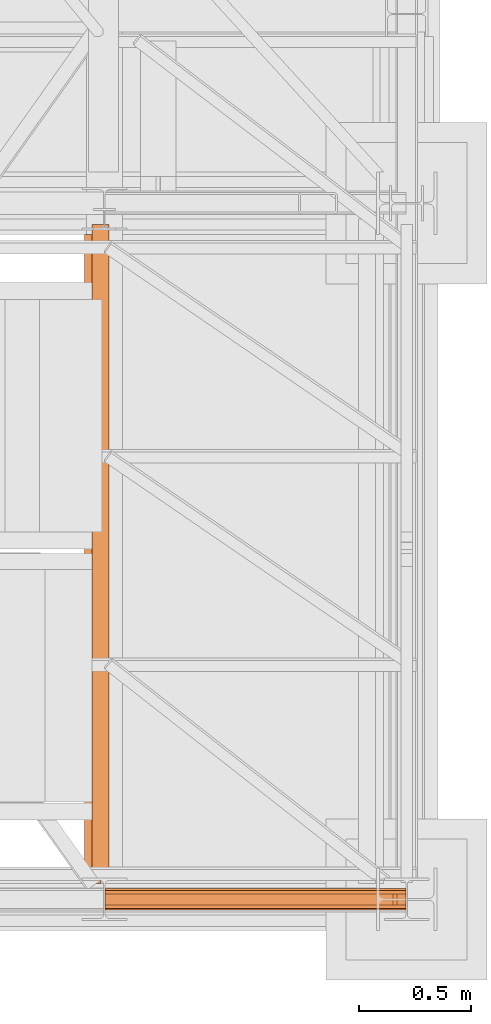
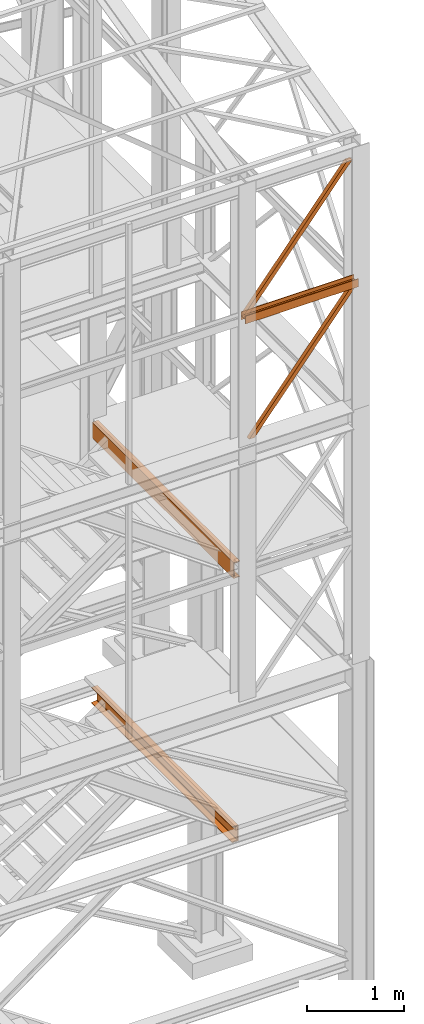
# One storey, part 47 of 208: 6 proxies.
"""IFC2X3 building model written with IfcOpenShell, lengths in millimetres."""

from ifc_helpers import new_model, entity, si_unit, converted_unit, frame, origin, origin_with_axes, place, context, subcontext, project, spatial, faceted_brep, element, save


model = new_model("IFC2X3")

# Units and contexts
model_context = context("Model", 3, precision=1e-05, world=origin())
plan_context = context("Plan", 3, precision=1e-05, world=origin())
body_context = subcontext(model_context, "Body", "Model", "MODEL_VIEW")
ifc_project = project(units=[si_unit("LENGTHUNIT", "METRE", prefix="MILLI"), converted_unit("PLANEANGLEUNIT", "DEGREE", entity("IfcPlaneAngleMeasure", 0.0174532925199433), si_unit("PLANEANGLEUNIT", "RADIAN"), dimensions=[0, 0, 0, 0, 0, 0, 0]), si_unit("AREAUNIT", "SQUARE_METRE"), si_unit("VOLUMEUNIT", "CUBIC_METRE")], contexts=[model_context, plan_context])

# Building, storey
building_placement = place(None, origin())
building = spatial("IfcBuilding", under=ifc_project, at=building_placement, CompositionType="COMPLEX")
storey_placement = place(building_placement, origin_with_axes())
storey = spatial("IfcBuildingStorey", under=building, at=storey_placement, Name="Geschoss", CompositionType="ELEMENT")

# Proxies
proxy_1_placement = place(storey_placement, frame((5351.504968595713, -25220.57439031787, 9979.990000745052), z_axis=(0.0, 0.0, 1.0), x_axis=(1.0, 0.0, 0.0)))
element("IfcBuildingElementProxy", 1, at=proxy_1_placement, inside=storey, context=body_context, shape_type="Brep", body=[
    faceted_brep([(0.01000000000021828, 8.0099999999984, 0.01000000000021828), (0.01000000000021828, 8.0099999999984, 47.51000000000022), (0.01000000000021828, 88.0099999999984, 47.51000000000022), (0.01000000000021828, 88.0099999999984, 0.01000000000021828), (0.01000000000021828, 96.0099999999984, 0.01000000000021828), (0.01000000000021828, 96.0099999999984, 100.0100000000002), (0.01000000000021828, 88.0099999999984, 100.0100000000002), (0.01000000000021828, 88.0099999999984, 52.51000000000022), (0.01000000000021828, 8.0099999999984, 52.51000000000022), (0.01000000000021828, 8.0099999999984, 100.0100000000002), (0.01000000000021828, 0.00999999999839929, 100.0100000000002), (0.01000000000021828, 0.00999999999839929, 0.01000000000021828), (0.01000000000021828, 0.00999999999839929, 0.01000000000021828), (1343.509999865887, 0.00999999999839929, 0.01000000000021828), (1343.509999865887, 8.0099999999984, 0.01000000000021828), (0.01000000000021828, 8.0099999999984, 0.01000000000021828), (0.01000000000021828, 0.00999999999839929, 100.0100000000002), (1343.509999865887, 0.00999999999839929, 100.0100000000002), (1343.509999865887, 0.00999999999839929, 0.01000000000021828), (0.01000000000021828, 0.00999999999839929, 0.01000000000021828), (0.01000000000021828, 8.0099999999984, 100.0100000000002), (1343.509999865887, 8.0099999999984, 100.0100000000002), (1343.509999865887, 0.00999999999839929, 100.0100000000002), (0.01000000000021828, 0.00999999999839929, 100.0100000000002), (0.01000000000021828, 8.0099999999984, 52.51000000000022), (1343.509999865887, 8.0099999999984, 52.51000000000022), (1343.509999865887, 8.0099999999984, 100.0100000000002), (0.01000000000021828, 8.0099999999984, 100.0100000000002), (0.01000000000021828, 88.0099999999984, 52.51000000000022), (1343.509999865887, 88.0099999999984, 52.51000000000022), (1343.509999865887, 8.0099999999984, 52.51000000000022), (0.01000000000021828, 8.0099999999984, 52.51000000000022), (0.01000000000021828, 88.0099999999984, 100.0100000000002), (1343.509999865887, 88.0099999999984, 100.0100000000002), (1343.509999865887, 88.0099999999984, 52.51000000000022), (0.01000000000021828, 88.0099999999984, 52.51000000000022), (0.01000000000021828, 96.0099999999984, 100.0100000000002), (1343.509999865887, 96.0099999999984, 100.0100000000002), (1343.509999865887, 88.0099999999984, 100.0100000000002), (0.01000000000021828, 88.0099999999984, 100.0100000000002), (0.01000000000021828, 96.0099999999984, 0.01000000000021828), (1343.509999865887, 96.0099999999984, 0.01000000000021828), (1343.509999865887, 96.0099999999984, 100.0100000000002), (0.01000000000021828, 96.0099999999984, 100.0100000000002), (0.01000000000021828, 88.0099999999984, 0.01000000000021828), (1343.509999865887, 88.0099999999984, 0.01000000000021828), (1343.509999865887, 96.0099999999984, 0.01000000000021828), (0.01000000000021828, 96.0099999999984, 0.01000000000021828), (0.01000000000021828, 88.0099999999984, 47.51000000000022), (1343.509999865887, 88.0099999999984, 47.51000000000022), (1343.509999865887, 88.0099999999984, 0.01000000000021828), (0.01000000000021828, 88.0099999999984, 0.01000000000021828), (0.01000000000021828, 8.0099999999984, 47.51000000000022), (1343.509999865887, 8.0099999999984, 47.51000000000022), (1343.509999865887, 88.0099999999984, 47.51000000000022), (0.01000000000021828, 88.0099999999984, 47.51000000000022), (0.01000000000021828, 8.0099999999984, 0.01000000000021828), (1343.509999865887, 8.0099999999984, 0.01000000000021828), (1343.509999865887, 8.0099999999984, 47.51000000000022), (0.01000000000021828, 8.0099999999984, 47.51000000000022), (1343.509999865887, 8.0099999999984, 0.01000000000021828), (1343.509999865887, 0.00999999999839929, 0.01000000000021828), (1343.509999865887, 0.00999999999839929, 100.0100000000002), (1343.509999865887, 8.0099999999984, 100.0100000000002), (1343.509999865887, 8.0099999999984, 52.51000000000022), (1343.509999865887, 88.0099999999984, 52.51000000000022), (1343.509999865887, 88.0099999999984, 100.0100000000002), (1343.509999865887, 96.0099999999984, 100.0100000000002), (1343.509999865887, 96.0099999999984, 0.01000000000021828), (1343.509999865887, 88.0099999999984, 0.01000000000021828), (1343.509999865887, 88.0099999999984, 47.51000000000022), (1343.509999865887, 8.0099999999984, 47.51000000000022)], [[[0, 1, 2, 3, 4, 5, 6, 7, 8, 9, 10, 11]], [[12, 13, 14, 15]], [[16, 17, 18, 19]], [[20, 21, 22, 23]], [[24, 25, 26, 27]], [[28, 29, 30, 31]], [[32, 33, 34, 35]], [[36, 37, 38, 39]], [[40, 41, 42, 43]], [[44, 45, 46, 47]], [[48, 49, 50, 51]], [[52, 53, 54, 55]], [[56, 57, 58, 59]], [[60, 61, 62, 63, 64, 65, 66, 67, 68, 69, 70, 71]]], orient=[[False], [False], [False], [False], [False], [False], [False], [False], [False], [False], [False], [False], [False], [False]]),
])
proxy_2_placement = place(storey_placement, frame((5409.555422962857, -25197.57439069041, 8496.989995894723), z_axis=(0.0, 0.0, 1.0), x_axis=(1.0, 0.0, 0.0)))
element("IfcBuildingElementProxy", 2, at=proxy_2_placement, inside=storey, context=body_context, shape_type="Brep", body=[
    faceted_brep([(0.009999999999308784, 50.01000074505646, 0.01000000000021828), (1244.693738884314, 50.01000074505646, 1530.51000485033), (1244.693738884314, 0.00999999999839929, 1530.51000485033), (0.01000000000112777, 0.00999999999839929, 0.01000000000021828), (64.45727517743671, 50.01000074505646, 0.01000000000021828), (1285.459545498749, 50.01000074505646, 1501.390569432124), (1285.459545498749, 50.01000074505646, 1530.51000485033), (1244.693738884314, 50.01000074505646, 1530.51000485033), (0.009999999999308784, 50.01000074505646, 0.01000000000021828), (64.45727517743671, 0.00999999999839929, 0.01000000000021828), (1285.45954549875, 0.00999999999839929, 1501.390569432124), (1285.459545498749, 50.01000074505646, 1501.390569432124), (64.45727517743671, 50.01000074505646, 0.01000000000021828), (0.01000000000112777, 0.00999999999839929, 0.01000000000021828), (1244.693738884314, 0.00999999999839929, 1530.51000485033), (1285.45954549875, 0.00999999999839929, 1530.510004850332), (1285.45954549875, 0.00999999999839929, 1501.390569432124), (64.45727517743671, 0.00999999999839929, 0.01000000000021828), (1244.693738884314, 0.00999999999839929, 1530.51000485033), (1244.693738884314, 50.01000074505646, 1530.51000485033), (1285.459545498749, 50.01000074505646, 1530.51000485033), (1285.45954549875, 0.00999999999839929, 1530.510004850332), (1285.459545498749, 50.01000074505646, 1530.51000485033), (1285.459545498749, 50.01000074505646, 1501.390569432124), (1285.45954549875, 0.00999999999839929, 1501.390569432124), (1285.45954549875, 0.00999999999839929, 1530.510004850332), (0.009999999999308784, 50.01000074505646, 0.01000000000021828), (0.01000000000112777, 0.00999999999839929, 0.01000000000021828), (64.45727517743671, 0.00999999999839929, 0.01000000000021828), (64.45727517743671, 50.01000074505646, 0.01000000000021828)], [[[0, 1, 2, 3]], [[4, 5, 6, 7, 8]], [[9, 10, 11, 12]], [[13, 14, 15, 16, 17]], [[18, 19, 20, 21]], [[22, 23, 24, 25]], [[26, 27, 28, 29]]], orient=[[False], [False], [False], [False], [False], [False], [False]]),
])
proxy_3_placement = place(storey_placement, frame((5351.504968595718, -25197.57439069041, 10044.49000051408), z_axis=(0.0, 0.0, 1.0), x_axis=(1.0, 0.0, 0.0)))
element("IfcBuildingElementProxy", 3, at=proxy_3_placement, inside=storey, context=body_context, shape_type="Brep", body=[
    faceted_brep([(0.01000000000112777, 0.00999999999839929, 41.12943667735271), (0.01000000000021828, 50.01000074505646, 41.12943667735271), (1220.994077882662, 50.01000074505646, 1542.487636147871), (1220.994077882662, 0.00999999999839929, 1542.487636147871), (0.01000000000021828, 50.01000074505646, 41.12943667735271), (0.01000000000021828, 50.01000074505646, 0.01000000000021828), (31.01676944585506, 50.01000074505646, 0.01000000000021828), (1285.459539439544, 50.01000074505646, 1542.509998658894), (1226.759995164574, 50.01000074505646, 1542.509998658894), (1220.994077882662, 50.01000074505646, 1542.487636147871), (31.01676944585506, 50.01000074505646, 0.01000000000021828), (31.01676944585506, 0.00999999999839929, 0.01000000000021828), (1285.459539439544, 0.00999999999839929, 1542.509998658894), (1285.459539439544, 50.01000074505646, 1542.509998658894), (0.01000000000021828, 0.00999999999839929, 0.01000000000021828), (0.01000000000112777, 0.00999999999839929, 41.12943667735271), (1220.994077882662, 0.00999999999839929, 1542.487636147871), (1226.759995164574, 0.00999999999839929, 1542.509998658894), (1285.459539439544, 0.00999999999839929, 1542.509998658894), (31.01676944585506, 0.00999999999839929, 0.01000000000021828), (1226.759995164574, 0.00999999999839929, 1542.509998658894), (1226.759995164574, 50.01000074505646, 1542.509998658894), (1285.459539439544, 50.01000074505646, 1542.509998658894), (1285.459539439544, 0.00999999999839929, 1542.509998658894), (1226.759995164574, 50.01000074505646, 1542.509998658894), (1226.759995164574, 0.00999999999839929, 1542.509998658894), (1220.994077882662, 0.00999999999839929, 1542.487636147871), (1220.994077882662, 50.01000074505646, 1542.487636147871), (0.01000000000021828, 50.01000074505646, 0.01000000000021828), (0.01000000000021828, 0.00999999999839929, 0.01000000000021828), (31.01676944585506, 0.00999999999839929, 0.01000000000021828), (31.01676944585506, 50.01000074505646, 0.01000000000021828), (0.01000000000021828, 50.01000074505646, 41.12943667735271), (0.01000000000112777, 0.00999999999839929, 41.12943667735271), (0.01000000000021828, 0.00999999999839929, 0.01000000000021828), (0.01000000000021828, 50.01000074505646, 0.01000000000021828)], [[[0, 1, 2, 3]], [[4, 5, 6, 7, 8, 9]], [[10, 11, 12, 13]], [[14, 15, 16, 17, 18, 19]], [[20, 21, 22, 23]], [[24, 25, 26, 27]], [[28, 29, 30, 31]], [[32, 33, 34, 35]]], orient=[[False], [False], [False], [False], [False], [False], [False], [False]]),
])
proxy_4_placement = place(storey_placement, frame((5351.504968595713, -25220.57439031787, 9979.990000745052), z_axis=(0.0, 0.0, 1.0), x_axis=(1.0, 0.0, 0.0)))
element("IfcBuildingElementProxy", 4, at=proxy_4_placement, inside=storey, context=body_context, shape_type="Brep", body=[
    faceted_brep([(0.01000000000021828, 8.0099999999984, 0.01000000000021828), (0.01000000000021828, 8.0099999999984, 47.51000000000022), (0.01000000000021828, 88.0099999999984, 47.51000000000022), (0.01000000000021828, 88.0099999999984, 0.01000000000021828), (0.01000000000021828, 96.0099999999984, 0.01000000000021828), (0.01000000000021828, 96.0099999999984, 100.0100000000002), (0.01000000000021828, 88.0099999999984, 100.0100000000002), (0.01000000000021828, 88.0099999999984, 52.51000000000022), (0.01000000000021828, 8.0099999999984, 52.51000000000022), (0.01000000000021828, 8.0099999999984, 100.0100000000002), (0.01000000000021828, 0.00999999999839929, 100.0100000000002), (0.01000000000021828, 0.00999999999839929, 0.01000000000021828), (0.01000000000021828, 0.00999999999839929, 0.01000000000021828), (1343.509999865887, 0.00999999999839929, 0.01000000000021828), (1343.509999865887, 8.0099999999984, 0.01000000000021828), (0.01000000000021828, 8.0099999999984, 0.01000000000021828), (0.01000000000021828, 0.00999999999839929, 100.0100000000002), (1343.509999865887, 0.00999999999839929, 100.0100000000002), (1343.509999865887, 0.00999999999839929, 0.01000000000021828), (0.01000000000021828, 0.00999999999839929, 0.01000000000021828), (0.01000000000021828, 8.0099999999984, 100.0100000000002), (1343.509999865887, 8.0099999999984, 100.0100000000002), (1343.509999865887, 0.00999999999839929, 100.0100000000002), (0.01000000000021828, 0.00999999999839929, 100.0100000000002), (0.01000000000021828, 8.0099999999984, 52.51000000000022), (1343.509999865887, 8.0099999999984, 52.51000000000022), (1343.509999865887, 8.0099999999984, 100.0100000000002), (0.01000000000021828, 8.0099999999984, 100.0100000000002), (0.01000000000021828, 88.0099999999984, 52.51000000000022), (1343.509999865887, 88.0099999999984, 52.51000000000022), (1343.509999865887, 8.0099999999984, 52.51000000000022), (0.01000000000021828, 8.0099999999984, 52.51000000000022), (0.01000000000021828, 88.0099999999984, 100.0100000000002), (1343.509999865887, 88.0099999999984, 100.0100000000002), (1343.509999865887, 88.0099999999984, 52.51000000000022), (0.01000000000021828, 88.0099999999984, 52.51000000000022), (0.01000000000021828, 96.0099999999984, 100.0100000000002), (1343.509999865887, 96.0099999999984, 100.0100000000002), (1343.509999865887, 88.0099999999984, 100.0100000000002), (0.01000000000021828, 88.0099999999984, 100.0100000000002), (0.01000000000021828, 96.0099999999984, 0.01000000000021828), (1343.509999865887, 96.0099999999984, 0.01000000000021828), (1343.509999865887, 96.0099999999984, 100.0100000000002), (0.01000000000021828, 96.0099999999984, 100.0100000000002), (0.01000000000021828, 88.0099999999984, 0.01000000000021828), (1343.509999865887, 88.0099999999984, 0.01000000000021828), (1343.509999865887, 96.0099999999984, 0.01000000000021828), (0.01000000000021828, 96.0099999999984, 0.01000000000021828), (0.01000000000021828, 88.0099999999984, 47.51000000000022), (1343.509999865887, 88.0099999999984, 47.51000000000022), (1343.509999865887, 88.0099999999984, 0.01000000000021828), (0.01000000000021828, 88.0099999999984, 0.01000000000021828), (0.01000000000021828, 8.0099999999984, 47.51000000000022), (1343.509999865887, 8.0099999999984, 47.51000000000022), (1343.509999865887, 88.0099999999984, 47.51000000000022), (0.01000000000021828, 88.0099999999984, 47.51000000000022), (0.01000000000021828, 8.0099999999984, 0.01000000000021828), (1343.509999865887, 8.0099999999984, 0.01000000000021828), (1343.509999865887, 8.0099999999984, 47.51000000000022), (0.01000000000021828, 8.0099999999984, 47.51000000000022), (1343.509999865887, 8.0099999999984, 0.01000000000021828), (1343.509999865887, 0.00999999999839929, 0.01000000000021828), (1343.509999865887, 0.00999999999839929, 100.0100000000002), (1343.509999865887, 8.0099999999984, 100.0100000000002), (1343.509999865887, 8.0099999999984, 52.51000000000022), (1343.509999865887, 88.0099999999984, 52.51000000000022), (1343.509999865887, 88.0099999999984, 100.0100000000002), (1343.509999865887, 96.0099999999984, 100.0100000000002), (1343.509999865887, 96.0099999999984, 0.01000000000021828), (1343.509999865887, 88.0099999999984, 0.01000000000021828), (1343.509999865887, 88.0099999999984, 47.51000000000022), (1343.509999865887, 8.0099999999984, 47.51000000000022)], [[[0, 1, 2, 3, 4, 5, 6, 7, 8, 9, 10, 11]], [[12, 13, 14, 15]], [[16, 17, 18, 19]], [[20, 21, 22, 23]], [[24, 25, 26, 27]], [[28, 29, 30, 31]], [[32, 33, 34, 35]], [[36, 37, 38, 39]], [[40, 41, 42, 43]], [[44, 45, 46, 47]], [[48, 49, 50, 51]], [[52, 53, 54, 55]], [[56, 57, 58, 59]], [[60, 61, 62, 63, 64, 65, 66, 67, 68, 69, 70, 71]]], orient=[[False], [False], [False], [False], [False], [False], [False], [False], [False], [False], [False], [False], [False], [False]]),
])
proxy_5_placement = place(storey_placement, frame((5293.401408260117, -25077.57437538436, 6709.989998509885), z_axis=(0.0, 0.0, 1.0), x_axis=(1.0, 0.0, 0.0)))
element("IfcBuildingElementProxy", 5, at=proxy_5_placement, inside=storey, context=body_context, shape_type="Brep", body=[
    faceted_brep([(0.01000000000021828, 2920.00998748303, 200.0100029802325), (0.01000000000021828, 2920.00998748303, 0.01000000000021828), (75.01000111758731, 2920.00998748303, 0.01000000000021828), (75.01000111758731, 2920.00998748303, 2.97083092689536), (73.89400100171588, 2920.00998748303, 7.368834147453526), (69.48847269475482, 2920.00998748303, 8.951724896431188), (19.09293180167697, 2920.00998748303, 12.98336816787742), (13.35380079060815, 2920.00998748303, 14.57858962774299), (9.50015002697728, 2920.00998748303, 18.85888857603095), (8.510000461936215, 2920.00998748303, 24.44674206733725), (8.510000461936215, 2920.00998748303, 175.5732609128954), (9.50015002697728, 2920.00998748303, 181.1611144042017), (13.35380079060815, 2920.00998748303, 185.4414133524897), (19.09293180167697, 2920.00998748303, 187.0366348123553), (69.48847269475482, 2920.00998748303, 191.0682780838015), (73.89400100171588, 2920.00998748303, 192.6511688327792), (75.01000111758731, 2920.00998748303, 197.0491720533373), (75.01000111758731, 2920.00998748303, 200.0100029802325), (0.01000000000021828, 2920.00998748303, 0.01000000000021828), (0.01000000000021828, 2920.00998748303, 200.0100029802325), (0.01000000000021828, 0.01000000000203727, 200.0100029802325), (0.01000000000021828, 0.01000000000203727, 0.01000000000021828), (75.01000111758731, 2920.00998748303, 0.01000000000021828), (0.01000000000021828, 2920.00998748303, 0.01000000000021828), (0.01000000000021828, 0.01000000000203727, 0.01000000000021828), (75.01000111758731, 0.01000000000203727, 0.01000000000021828), (75.01000111758731, 2920.00998748303, 2.97083092689536), (75.01000111758731, 2920.00998748303, 0.01000000000021828), (75.01000111758731, 0.01000000000203727, 0.01000000000021828), (75.01000111758731, 0.01000000000203727, 2.97083092689536), (73.89400100171588, 2920.00998748303, 7.368834147453526), (75.01000111758731, 2920.00998748303, 2.97083092689536), (75.01000111758731, 0.01000000000203727, 2.97083092689536), (73.89400100171588, 0.01000000000203727, 7.368834147453526), (69.48847269475482, 2920.00998748303, 8.951724896431188), (73.89400100171588, 2920.00998748303, 7.368834147453526), (73.89400100171588, 0.01000000000203727, 7.368834147453526), (69.48847269475482, 0.01000000000203727, 8.951724896431188), (19.09293180167697, 2920.00998748303, 12.98336816787742), (69.48847269475482, 2920.00998748303, 8.951724896431188), (69.48847269475482, 0.01000000000203727, 8.951724896431188), (19.09293180167697, 0.01000000000203727, 12.98336816787742), (13.35380079060815, 2920.00998748303, 14.57858962774299), (19.09293180167697, 2920.00998748303, 12.98336816787742), (19.09293180167697, 0.01000000000203727, 12.98336816787742), (13.35380079060815, 0.01000000000203727, 14.57858962774299), (9.50015002697728, 2920.00998748303, 18.85888857603095), (13.35380079060815, 2920.00998748303, 14.57858962774299), (13.35380079060815, 0.01000000000203727, 14.57858962774299), (9.50015002697728, 0.01000000000203727, 18.85888857603095), (8.510000461936215, 2920.00998748303, 24.44674206733725), (9.50015002697728, 2920.00998748303, 18.85888857603095), (9.50015002697728, 0.01000000000203727, 18.85888857603095), (8.510000461936215, 0.01000000000203727, 24.44674206733725), (8.510000461936215, 2920.00998748303, 175.5732609128954), (8.510000461936215, 2920.00998748303, 24.44674206733725), (8.510000461936215, 0.01000000000203727, 24.44674206733725), (8.510000461936215, 0.01000000000203727, 175.5732609128954), (9.50015002697728, 2920.00998748303, 181.1611144042017), (8.510000461936215, 2920.00998748303, 175.5732609128954), (8.510000461936215, 0.01000000000203727, 175.5732609128954), (9.50015002697728, 0.01000000000203727, 181.1611144042017), (13.35380079060815, 2920.00998748303, 185.4414133524897), (9.50015002697728, 2920.00998748303, 181.1611144042017), (9.50015002697728, 0.01000000000203727, 181.1611144042017), (13.35380079060815, 0.01000000000203727, 185.4414133524897), (19.09293180167697, 2920.00998748303, 187.0366348123553), (13.35380079060815, 2920.00998748303, 185.4414133524897), (13.35380079060815, 0.01000000000203727, 185.4414133524897), (19.09293180167697, 0.01000000000203727, 187.0366348123553), (69.48847269475482, 2920.00998748303, 191.0682780838015), (19.09293180167697, 2920.00998748303, 187.0366348123553), (19.09293180167697, 0.01000000000203727, 187.0366348123553), (69.48847269475482, 0.01000000000203727, 191.0682780838015), (73.89400100171588, 2920.00998748303, 192.6511688327792), (69.48847269475482, 2920.00998748303, 191.0682780838015), (69.48847269475482, 0.01000000000203727, 191.0682780838015), (73.89400100171588, 0.01000000000203727, 192.6511688327792), (75.01000111758731, 2920.00998748303, 197.0491720533373), (73.89400100171588, 2920.00998748303, 192.6511688327792), (73.89400100171588, 0.01000000000203727, 192.6511688327792), (75.01000111758731, 0.01000000000203727, 197.0491720533373), (75.01000111758731, 2920.00998748303, 200.0100029802325), (75.01000111758731, 2920.00998748303, 197.0491720533373), (75.01000111758731, 0.01000000000203727, 197.0491720533373), (75.01000111758731, 0.01000000000203727, 200.0100029802325), (0.01000000000021828, 2920.00998748303, 200.0100029802325), (75.01000111758731, 2920.00998748303, 200.0100029802325), (75.01000111758731, 0.01000000000203727, 200.0100029802325), (0.01000000000021828, 0.01000000000203727, 200.0100029802325), (0.01000000000021828, 0.01000000000203727, 200.0100029802325), (75.01000111758731, 0.01000000000203727, 200.0100029802325), (75.01000111758731, 0.01000000000203727, 197.0491720533373), (73.89400100171588, 0.01000000000203727, 192.6511688327792), (69.48847269475482, 0.01000000000203727, 191.0682780838015), (19.09293180167697, 0.01000000000203727, 187.0366348123553), (13.35380079060815, 0.01000000000203727, 185.4414133524897), (9.50015002697728, 0.01000000000203727, 181.1611144042017), (8.510000461936215, 0.01000000000203727, 175.5732609128954), (8.510000461936215, 0.01000000000203727, 24.44674206733725), (9.50015002697728, 0.01000000000203727, 18.85888857603095), (13.35380079060815, 0.01000000000203727, 14.57858962774299), (19.09293180167697, 0.01000000000203727, 12.98336816787742), (69.48847269475482, 0.01000000000203727, 8.951724896431188), (73.89400100171588, 0.01000000000203727, 7.368834147453526), (75.01000111758731, 0.01000000000203727, 2.97083092689536), (75.01000111758731, 0.01000000000203727, 0.01000000000021828), (0.01000000000021828, 0.01000000000203727, 0.01000000000021828)], [[[0, 1, 2, 3, 4, 5, 6, 7, 8, 9, 10, 11, 12, 13, 14, 15, 16, 17]], [[18, 19, 20, 21]], [[22, 23, 24, 25]], [[26, 27, 28, 29]], [[30, 31, 32, 33]], [[34, 35, 36, 37]], [[38, 39, 40, 41]], [[42, 43, 44, 45]], [[46, 47, 48, 49]], [[50, 51, 52, 53]], [[54, 55, 56, 57]], [[58, 59, 60, 61]], [[62, 63, 64, 65]], [[66, 67, 68, 69]], [[70, 71, 72, 73]], [[74, 75, 76, 77]], [[78, 79, 80, 81]], [[82, 83, 84, 85]], [[86, 87, 88, 89]], [[90, 91, 92, 93, 94, 95, 96, 97, 98, 99, 100, 101, 102, 103, 104, 105, 106, 107]]], orient=[[False], [False], [False], [False], [False], [False], [False], [False], [False], [False], [False], [False], [False], [False], [False], [False], [False], [False], [False], [False]]),
])
proxy_6_placement = place(storey_placement, frame((5258.401408260117, -25102.57439001986, 3413.989998509884), z_axis=(0.0, 0.0, 1.0), x_axis=(1.0, 0.0, 0.0)))
element("IfcBuildingElementProxy", 6, at=proxy_6_placement, inside=storey, context=body_context, shape_type="Brep", body=[
    faceted_brep([(75.01000111758731, 2900.009999105929, 0.01000000000021828), (75.01000111758731, 0.00999999999839929, 0.01000000000067303), (75.01000111758731, 0.00999999999839929, 200.0100029802329), (75.01000111758731, 2900.009999105929, 200.0100029802329), (0.01000000000021828, 2900.009999105929, 0.01000000000021828), (0.01000000000021828, 0.00999999999839929, 0.01000000000067303), (75.01000111758731, 0.00999999999839929, 0.01000000000067303), (75.01000111758731, 2900.009999105929, 0.01000000000021828), (0.01000000000021828, 2900.009999105929, 2.970830926895815), (0.01000000000021828, 0.00999999999839929, 2.970830926895815), (0.01000000000021828, 0.00999999999839929, 0.01000000000067303), (0.01000000000021828, 2900.009999105929, 0.01000000000021828), (1.126000115871648, 2900.009999105929, 7.368834147453981), (1.126000115871648, 0.00999999999839929, 7.368834147453981), (0.01000000000021828, 0.00999999999839929, 2.970830926895815), (0.01000000000021828, 2900.009999105929, 2.970830926895815), (5.531528422832707, 2900.009999105929, 8.951724896431642), (5.531528422832707, 0.00999999999839929, 8.951724896431642), (1.126000115871648, 0.00999999999839929, 7.368834147453981), (1.126000115871648, 2900.009999105929, 7.368834147453981), (55.92706931591056, 2900.009999105929, 12.98336816787787), (55.92706931591056, 0.00999999999839929, 12.98336816787787), (5.531528422832707, 0.00999999999839929, 8.951724896431642), (5.531528422832707, 2900.009999105929, 8.951724896431642), (61.66620032697938, 2900.009999105929, 14.57858962774344), (61.66620032697938, 0.00999999999839929, 14.57858962774344), (55.92706931591056, 0.00999999999839929, 12.98336816787787), (55.92706931591056, 2900.009999105929, 12.98336816787787), (65.51985109061025, 2900.009999105929, 18.8588885760314), (65.51985109061025, 0.00999999999839929, 18.8588885760314), (61.66620032697938, 0.00999999999839929, 14.57858962774344), (61.66620032697938, 2900.009999105929, 14.57858962774344), (66.51000065565131, 2900.009999105929, 24.44674206733725), (66.51000065565131, 0.00999999999839929, 24.44674206733771), (65.51985109061025, 0.00999999999839929, 18.8588885760314), (65.51985109061025, 2900.009999105929, 18.8588885760314), (66.51000065565131, 2900.009999105929, 175.5732609128959), (66.51000065565131, 0.00999999999839929, 175.5732609128959), (66.51000065565131, 0.00999999999839929, 24.44674206733771), (66.51000065565131, 2900.009999105929, 24.44674206733725), (65.51985109061025, 2900.009999105929, 181.1611144042022), (65.51985109061025, 0.00999999999839929, 181.1611144042022), (66.51000065565131, 0.00999999999839929, 175.5732609128959), (66.51000065565131, 2900.009999105929, 175.5732609128959), (61.66620032697938, 2900.009999105929, 185.4414133524901), (61.66620032697938, 0.00999999999839929, 185.4414133524901), (65.51985109061025, 0.00999999999839929, 181.1611144042022), (65.51985109061025, 2900.009999105929, 181.1611144042022), (55.92706931591056, 2900.009999105929, 187.0366348123557), (55.92706931591056, 0.00999999999839929, 187.0366348123557), (61.66620032697938, 0.00999999999839929, 185.4414133524901), (61.66620032697938, 2900.009999105929, 185.4414133524901), (5.531528422832707, 2900.009999105929, 191.0682780838019), (5.531528422832707, 0.00999999999839929, 191.0682780838019), (55.92706931591056, 0.00999999999839929, 187.0366348123557), (55.92706931591056, 2900.009999105929, 187.0366348123557), (1.126000115871648, 2900.009999105929, 192.6511688327792), (1.126000115871648, 0.00999999999839929, 192.6511688327796), (5.531528422832707, 0.00999999999839929, 191.0682780838019), (5.531528422832707, 2900.009999105929, 191.0682780838019), (0.01000000000021828, 2900.009999105929, 197.0491720533378), (0.01000000000021828, 0.00999999999839929, 197.0491720533378), (1.126000115871648, 0.00999999999839929, 192.6511688327796), (1.126000115871648, 2900.009999105929, 192.6511688327792), (0.01000000000021828, 2900.009999105929, 200.0100029802329), (0.01000000000021828, 0.00999999999839929, 200.0100029802329), (0.01000000000021828, 0.00999999999839929, 197.0491720533378), (0.01000000000021828, 2900.009999105929, 197.0491720533378), (75.01000111758731, 2900.009999105929, 200.0100029802329), (75.01000111758731, 0.00999999999839929, 200.0100029802329), (0.01000000000021828, 0.00999999999839929, 200.0100029802329), (0.01000000000021828, 2900.009999105929, 200.0100029802329), (75.01000111758731, 0.00999999999839929, 200.0100029802329), (75.01000111758731, 0.00999999999839929, 0.01000000000067303), (0.01000000000021828, 0.00999999999839929, 0.01000000000067303), (0.01000000000021828, 0.00999999999839929, 2.970830926895815), (1.126000115871648, 0.00999999999839929, 7.368834147453981), (5.531528422832707, 0.00999999999839929, 8.951724896431642), (55.92706931591056, 0.00999999999839929, 12.98336816787787), (61.66620032697938, 0.00999999999839929, 14.57858962774344), (65.51985109061025, 0.00999999999839929, 18.8588885760314), (66.51000065565131, 0.00999999999839929, 24.44674206733771), (66.51000065565131, 0.00999999999839929, 175.5732609128959), (65.51985109061025, 0.00999999999839929, 181.1611144042022), (61.66620032697938, 0.00999999999839929, 185.4414133524901), (55.92706931591056, 0.00999999999839929, 187.0366348123557), (5.531528422832707, 0.00999999999839929, 191.0682780838019), (1.126000115871648, 0.00999999999839929, 192.6511688327796), (0.01000000000021828, 0.00999999999839929, 197.0491720533378), (0.01000000000021828, 0.00999999999839929, 200.0100029802329), (75.01000111758731, 2900.009999105929, 200.0100029802329), (0.01000000000021828, 2900.009999105929, 200.0100029802329), (0.01000000000021828, 2900.009999105929, 197.0491720533378), (1.126000115871648, 2900.009999105929, 192.6511688327792), (5.531528422832707, 2900.009999105929, 191.0682780838019), (55.92706931591056, 2900.009999105929, 187.0366348123557), (61.66620032697938, 2900.009999105929, 185.4414133524901), (65.51985109061025, 2900.009999105929, 181.1611144042022), (66.51000065565131, 2900.009999105929, 175.5732609128959), (66.51000065565131, 2900.009999105929, 24.44674206733725), (65.51985109061025, 2900.009999105929, 18.8588885760314), (61.66620032697938, 2900.009999105929, 14.57858962774344), (55.92706931591056, 2900.009999105929, 12.98336816787787), (5.531528422832707, 2900.009999105929, 8.951724896431642), (1.126000115871648, 2900.009999105929, 7.368834147453981), (0.01000000000021828, 2900.009999105929, 2.970830926895815), (0.01000000000021828, 2900.009999105929, 0.01000000000021828), (75.01000111758731, 2900.009999105929, 0.01000000000021828)], [[[0, 1, 2, 3]], [[4, 5, 6, 7]], [[8, 9, 10, 11]], [[12, 13, 14, 15]], [[16, 17, 18, 19]], [[20, 21, 22, 23]], [[24, 25, 26, 27]], [[28, 29, 30, 31]], [[32, 33, 34, 35]], [[36, 37, 38, 39]], [[40, 41, 42, 43]], [[44, 45, 46, 47]], [[48, 49, 50, 51]], [[52, 53, 54, 55]], [[56, 57, 58, 59]], [[60, 61, 62, 63]], [[64, 65, 66, 67]], [[68, 69, 70, 71]], [[72, 73, 74, 75, 76, 77, 78, 79, 80, 81, 82, 83, 84, 85, 86, 87, 88, 89]], [[90, 91, 92, 93, 94, 95, 96, 97, 98, 99, 100, 101, 102, 103, 104, 105, 106, 107]]], orient=[[False], [False], [False], [False], [False], [False], [False], [False], [False], [False], [False], [False], [False], [False], [False], [False], [False], [False], [False], [False]]),
])

save(model, "model.ifc")
